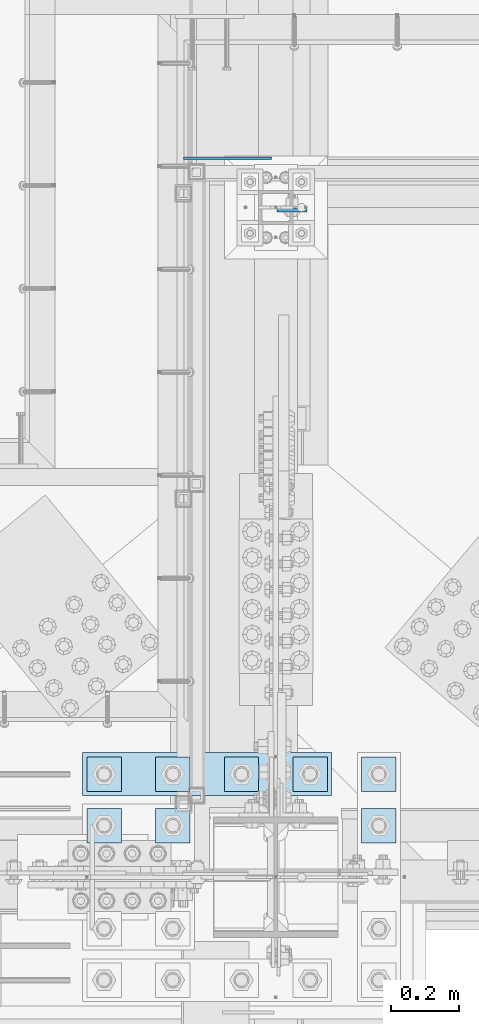
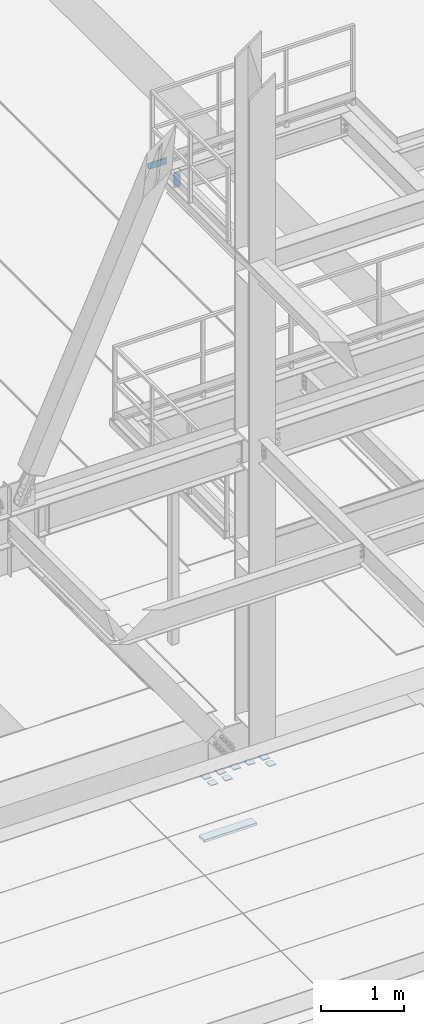
# One storey, part 3139 of 3843: 11 plates, 2 elements without a shape of their own.
"""IFC2X3 building model written with IfcOpenShell, lengths in millimetres."""

from ifc_helpers import new_model, si_unit, frame, origin_with_axes, place, context, subcontext, project, spatial, faceted_brep, material, type_object, element, aggregate, save


model = new_model("IFC2X3")

# Units and contexts
model_context = context("Model", 3, precision=1e-05, world=origin_with_axes())
body_context = subcontext(model_context, "Body", "Model", "MODEL_VIEW")
ifc_project = project(units=[si_unit("LENGTHUNIT", "METRE", prefix="MILLI"), si_unit("AREAUNIT", "SQUARE_METRE"), si_unit("VOLUMEUNIT", "CUBIC_METRE"), si_unit("MASSUNIT", "GRAM", prefix="KILO"), si_unit("TIMEUNIT", "SECOND"), si_unit("PLANEANGLEUNIT", "RADIAN"), si_unit("SOLIDANGLEUNIT", "STERADIAN"), si_unit("THERMODYNAMICTEMPERATUREUNIT", "DEGREE_CELSIUS"), si_unit("LUMINOUSINTENSITYUNIT", "LUMEN")], contexts=[model_context])

# Site, building, storey
site_placement = place(None, origin_with_axes())
site = spatial("IfcSite", under=ifc_project, at=site_placement, CompositionType="ELEMENT")
building_placement = place(site_placement, origin_with_axes())
building = spatial("IfcBuilding", under=site, at=building_placement, Name="Undefined", CompositionType="ELEMENT")
storey_placement = place(building_placement, origin_with_axes())
storey = spatial("IfcBuildingStorey", under=building, at=storey_placement, Name="Undefined", CompositionType="ELEMENT", Elevation=0.0)

# Assembly, plates
assembly_1_placement = place(storey_placement, origin_with_axes())
assembly_1 = element("IfcElementAssembly", 1, at=assembly_1_placement, inside=storey, Name="BEAM", AssemblyPlace="NOTDEFINED", PredefinedType="RIGID_FRAME")
ifc_material = material(Name="STEEL/A572-50")
plate_type_1 = type_object("IfcPlateType", PredefinedType="NOTDEFINED")
plate_1_placement = place(assembly_1_placement, frame((48999.775, 27589.1625, 37426.9), z_axis=(1.0, 0.0, 0.0), x_axis=(0.0, 0.0, -1.0)))
plate_1 = element("IfcPlate", 2, at=plate_1_placement, type_object=plate_type_1, material=ifc_material, Name="PLATE", context=body_context, shape_type="Brep", body=[
    faceted_brep([(0.0, -4.76249999999709, 0.0), (0.0, -4.76249999999709, 88.9000015258789), (0.0, 4.76249999999709, 88.9000015258789), (0.0, 4.76249999999709, 0.0), (228.600006102781, -4.7625000004191, 88.9000015257589), (228.600006102781, 4.76249999954598, 88.9000015257443), (228.600006103079, -4.7625000004482, 7.27595761418343e-12), (228.600006103079, 4.76249999954598, -7.27595761418343e-12)], [[[0, 1, 2, 3]], [[1, 4, 5, 2]], [[4, 6, 7, 5]], [[6, 0, 3, 7]], [[5, 7, 3, 2]], [[6, 4, 1, 0]]]),
])
plate_type_2 = type_object("IfcPlateType", PredefinedType="NOTDEFINED")
plate_2_placement = place(assembly_1_placement, frame((48723.55, 27743.1497862042, 37471.35), z_axis=(0.0, 0.0, 1.0), x_axis=(1.0, 0.0, 0.0)))
plate_2 = element("IfcPlate", 3, at=plate_2_placement, type_object=plate_type_2, material=ifc_material, Name="PLATE", context=body_context, shape_type="Brep", body=[
    faceted_brep([(4.36557456851006e-11, -3.17499999998836, 19.0499992370969), (0.0, -3.17499999999927, 95.25), (-2.44140610448085e-05, 3.17500000000291, 95.2499999999927), (1.45519152283669e-11, 3.17499999998836, 19.0499992370824), (260.350006103516, -3.17499999999927, 95.25), (260.350006103516, 3.17499999999927, 95.25), (260.350006103516, -3.17499999999927, 0.0), (260.350006103516, 3.17499999999927, 0.0), (19.0499992370023, -3.17500000005384, 0.0), (19.0499992369587, 3.17499999992287, -1.45519152283669e-11)], [[[0, 1, 2, 3]], [[1, 4, 5, 2]], [[4, 6, 7, 5]], [[6, 8, 9, 7]], [[8, 0, 3, 9]], [[5, 7, 9, 3, 2]], [[8, 6, 4, 1, 0]]]),
])
aggregate(assembly_1, [plate_2, plate_1])

assembly_2_placement = place(storey_placement, origin_with_axes())
assembly_2 = element("IfcElementAssembly", 4, at=assembly_2_placement, inside=storey, Name="TEMPLATE", AssemblyPlace="NOTDEFINED", PredefinedType="RIGID_FRAME")
plate_type_3 = type_object("IfcPlateType", PredefinedType="NOTDEFINED")
plate_3_placement = place(assembly_2_placement, frame((48539.4, 25819.1, 29686.25), z_axis=(-1.0, 0.0, 0.0), x_axis=(0.0, -1.0, 0.0)))
plate_3 = element("IfcPlate", 5, at=plate_3_placement, type_object=plate_type_3, material=ifc_material, Name="Washer Plate", context=body_context, shape_type="Brep", body=[
    faceted_brep([(0.0, -6.3499999046162, 0.0), (-1.67347025126219e-10, -6.35000000000582, 101.600000000151), (-1.67347025126219e-10, 6.35000000000582, 101.600000000151), (7.27595761418343e-12, 6.3499999046162, 0.0), (101.599998474121, -6.34999999999854, 101.599998474121), (101.599998474121, 6.34999999999854, 101.599998474121), (101.6, -6.34999999999854, 0.0), (101.6, 6.34999999999854, 0.0)], [[[0, 1, 2, 3]], [[1, 4, 5, 2]], [[4, 6, 7, 5]], [[6, 0, 3, 7]], [[5, 7, 3, 2]], [[6, 4, 1, 0]]]),
])
plate_4_placement = place(assembly_2_placement, frame((48742.6, 25819.1, 29686.25), z_axis=(-1.0, 0.0, 0.0), x_axis=(0.0, -1.0, 0.0)))
plate_4 = element("IfcPlate", 6, at=plate_4_placement, type_object=plate_type_3, material=ifc_material, Name="Washer Plate", context=body_context, shape_type="Brep", body=[
    faceted_brep([(0.0, -6.3499999046162, 0.0), (-1.67347025126219e-10, -6.35000000000582, 101.600000000151), (-1.67347025126219e-10, 6.35000000000582, 101.600000000151), (7.27595761418343e-12, 6.3499999046162, 0.0), (101.599998474121, -6.34999999999854, 101.599998474121), (101.599998474121, 6.34999999999854, 101.599998474121), (101.6, -6.34999999999854, 0.0), (101.6, 6.34999999999854, 0.0)], [[[0, 1, 2, 3]], [[1, 4, 5, 2]], [[4, 6, 7, 5]], [[6, 0, 3, 7]], [[5, 7, 3, 2]], [[6, 4, 1, 0]]]),
])
plate_5_placement = place(assembly_2_placement, frame((49352.2, 25819.1, 29686.25), z_axis=(-1.0, 0.0, 0.0), x_axis=(0.0, -1.0, 0.0)))
plate_5 = element("IfcPlate", 7, at=plate_5_placement, type_object=plate_type_3, material=ifc_material, Name="Washer Plate", context=body_context, shape_type="Brep", body=[
    faceted_brep([(0.0, -6.3499999046162, 0.0), (-1.67347025126219e-10, -6.35000000000582, 101.600000000151), (-1.67347025126219e-10, 6.35000000000582, 101.600000000151), (7.27595761418343e-12, 6.3499999046162, 0.0), (101.599998474121, -6.34999999999854, 101.599998474121), (101.599998474121, 6.34999999999854, 101.599998474121), (101.6, -6.34999999999854, 0.0), (101.6, 6.34999999999854, 0.0)], [[[0, 1, 2, 3]], [[1, 4, 5, 2]], [[4, 6, 7, 5]], [[6, 0, 3, 7]], [[5, 7, 3, 2]], [[6, 4, 1, 0]]]),
])
plate_6_placement = place(assembly_2_placement, frame((48539.4, 25971.5, 29686.25), z_axis=(-1.0, 0.0, 0.0), x_axis=(0.0, -1.0, 0.0)))
plate_6 = element("IfcPlate", 8, at=plate_6_placement, type_object=plate_type_3, material=ifc_material, Name="Washer Plate", context=body_context, shape_type="Brep", body=[
    faceted_brep([(0.0, -6.3499999046162, 0.0), (-1.67347025126219e-10, -6.35000000000582, 101.600000000151), (-1.67347025126219e-10, 6.35000000000582, 101.600000000151), (7.27595761418343e-12, 6.3499999046162, 0.0), (101.599998474121, -6.34999999999854, 101.599998474121), (101.599998474121, 6.34999999999854, 101.599998474121), (101.6, -6.34999999999854, 0.0), (101.6, 6.34999999999854, 0.0)], [[[0, 1, 2, 3]], [[1, 4, 5, 2]], [[4, 6, 7, 5]], [[6, 0, 3, 7]], [[5, 7, 3, 2]], [[6, 4, 1, 0]]]),
])
plate_7_placement = place(assembly_2_placement, frame((48742.6, 25971.5, 29686.25), z_axis=(-1.0, 0.0, 0.0), x_axis=(0.0, -1.0, 0.0)))
plate_7 = element("IfcPlate", 9, at=plate_7_placement, type_object=plate_type_3, material=ifc_material, Name="Washer Plate", context=body_context, shape_type="Brep", body=[
    faceted_brep([(0.0, -6.3499999046162, 0.0), (-1.67347025126219e-10, -6.35000000000582, 101.600000000151), (-1.67347025126219e-10, 6.35000000000582, 101.600000000151), (7.27595761418343e-12, 6.3499999046162, 0.0), (101.599998474121, -6.34999999999854, 101.599998474121), (101.599998474121, 6.34999999999854, 101.599998474121), (101.6, -6.34999999999854, 0.0), (101.6, 6.34999999999854, 0.0)], [[[0, 1, 2, 3]], [[1, 4, 5, 2]], [[4, 6, 7, 5]], [[6, 0, 3, 7]], [[5, 7, 3, 2]], [[6, 4, 1, 0]]]),
])
plate_8_placement = place(assembly_2_placement, frame((48945.8, 25971.5, 29686.25), z_axis=(-1.0, 0.0, 0.0), x_axis=(0.0, -1.0, 0.0)))
plate_8 = element("IfcPlate", 10, at=plate_8_placement, type_object=plate_type_3, material=ifc_material, Name="Washer Plate", context=body_context, shape_type="Brep", body=[
    faceted_brep([(0.0, -6.3499999046162, 0.0), (-1.67347025126219e-10, -6.35000000000582, 101.600000000151), (-1.67347025126219e-10, 6.35000000000582, 101.600000000151), (7.27595761418343e-12, 6.3499999046162, 0.0), (101.599998474121, -6.34999999999854, 101.599998474121), (101.599998474121, 6.34999999999854, 101.599998474121), (101.6, -6.34999999999854, 0.0), (101.6, 6.34999999999854, 0.0)], [[[0, 1, 2, 3]], [[1, 4, 5, 2]], [[4, 6, 7, 5]], [[6, 0, 3, 7]], [[5, 7, 3, 2]], [[6, 4, 1, 0]]]),
])
plate_9_placement = place(assembly_2_placement, frame((49149.0, 25971.5, 29686.25), z_axis=(-1.0, 0.0, 0.0), x_axis=(0.0, -1.0, 0.0)))
plate_9 = element("IfcPlate", 11, at=plate_9_placement, type_object=plate_type_3, material=ifc_material, Name="Washer Plate", context=body_context, shape_type="Brep", body=[
    faceted_brep([(0.0, -6.3499999046162, 0.0), (-1.67347025126219e-10, -6.35000000000582, 101.600000000151), (-1.67347025126219e-10, 6.35000000000582, 101.600000000151), (7.27595761418343e-12, 6.3499999046162, 0.0), (101.599998474121, -6.34999999999854, 101.599998474121), (101.599998474121, 6.34999999999854, 101.599998474121), (101.6, -6.34999999999854, 0.0), (101.6, 6.34999999999854, 0.0)], [[[0, 1, 2, 3]], [[1, 4, 5, 2]], [[4, 6, 7, 5]], [[6, 0, 3, 7]], [[5, 7, 3, 2]], [[6, 4, 1, 0]]]),
])
plate_10_placement = place(assembly_2_placement, frame((49352.2, 25971.5, 29686.25), z_axis=(-1.0, 0.0, 0.0), x_axis=(0.0, -1.0, 0.0)))
plate_10 = element("IfcPlate", 12, at=plate_10_placement, type_object=plate_type_3, material=ifc_material, Name="Washer Plate", context=body_context, shape_type="Brep", body=[
    faceted_brep([(0.0, -6.3499999046162, 0.0), (-1.67347025126219e-10, -6.35000000000582, 101.600000000151), (-1.67347025126219e-10, 6.35000000000582, 101.600000000151), (7.27595761418343e-12, 6.3499999046162, 0.0), (101.599998474121, -6.34999999999854, 101.599998474121), (101.599998474121, 6.34999999999854, 101.599998474121), (101.6, -6.34999999999854, 0.0), (101.6, 6.34999999999854, 0.0)], [[[0, 1, 2, 3]], [[1, 4, 5, 2]], [[4, 6, 7, 5]], [[6, 0, 3, 7]], [[5, 7, 3, 2]], [[6, 4, 1, 0]]]),
])
plate_type_4 = type_object("IfcPlateType", PredefinedType="NOTDEFINED")
plate_11_placement = place(assembly_2_placement, frame((49161.7, 25984.2, 28784.55), z_axis=(-1.0, 0.0, 0.0), x_axis=(0.0, -1.0, 0.0)))
plate_11 = element("IfcPlate", 13, at=plate_11_placement, type_object=plate_type_4, material=ifc_material, Name="PLATE", context=body_context, shape_type="Brep", body=[
    faceted_brep([(0.0, -19.0500000000029, 0.0), (0.0, -19.0499999999993, 736.600036621094), (0.0, 19.0499999999993, 736.600036621094), (0.0, 19.0500000000029, 0.0), (127.0, -19.0499999999993, 736.600036621094), (127.0, 19.0499999999993, 736.600036621094), (127.0, -19.0499999999993, 0.0), (127.0, 19.0499999999993, 0.0)], [[[0, 1, 2, 3]], [[1, 4, 5, 2]], [[4, 6, 7, 5]], [[6, 0, 3, 7]], [[5, 7, 3, 2]], [[6, 4, 1, 0]]]),
])
aggregate(assembly_2, [plate_11, plate_3, plate_4, plate_5, plate_6, plate_7, plate_8, plate_9, plate_10])

save(model, "model.ifc")
